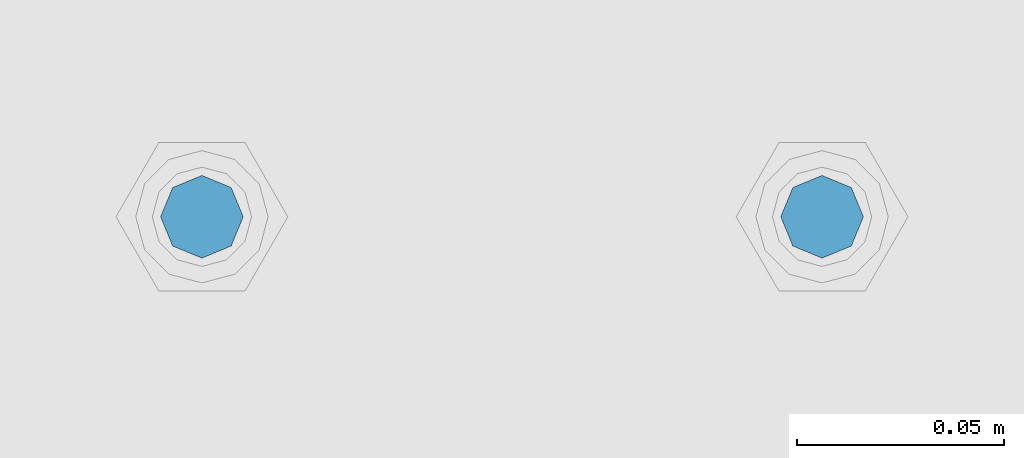
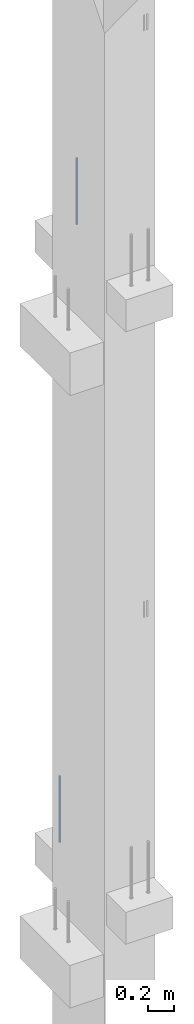
# One storey, part 14 of 41: 2 beams, 1 element without a shape of its own.
"""IFC2X3 building model written with IfcOpenShell, lengths in millimetres."""

import ifcopenshell
import ifcopenshell.guid

model = None  # the IFC model being written
_history = None  # IfcOwnerHistory: only IFC2X3 demands one
_inside = {}  # id of a spatial element -> (the spatial element, [elements in it])
_under = {}  # id of a project, library or spatial element -> (it, [spatial elements below it])
_declared = {}  # id of a project -> (the project, [libraries it declares])
_typed = {}  # id of a type object -> (the type object, [elements of that type])
_made_of = {}  # id of a material, layer set ... -> (it, [elements and type objects made of it])


def new_model(schema):
    """Start an empty IFC model of exactly this schema.

    Asked for "IFC4X3", IfcOpenShell would pick the latest addendum, in which some entities
    have other attributes; the version numbers below select the first issue.
    IFC2X3 requires an IfcOwnerHistory on every rooted entity: one is made here for all.
    """
    global model, _history
    if schema == "IFC4X3":
        model = ifcopenshell.file(schema_version=(4, 3, 0, 0))
    else:
        model = ifcopenshell.file(schema=schema)
    _inside.clear()
    _under.clear()
    _declared.clear()
    _typed.clear()
    _made_of.clear()
    _history = None
    if model.schema == "IFC2X3":
        org = make("IfcOrganization", Name="unknown")
        user = make(
            "IfcPersonAndOrganization",
            ThePerson=make("IfcPerson", FamilyName="unknown"),
            TheOrganization=org,
        )
        app = make(
            "IfcApplication",
            ApplicationDeveloper=org,
            Version="unknown",
            ApplicationFullName="unknown",
            ApplicationIdentifier="unknown",
        )
        _history = make(
            "IfcOwnerHistory",
            OwningUser=user,
            OwningApplication=app,
            ChangeAction="ADDED",
            CreationDate=0,
        )
    return model


def make(cls, **values):
    """One entity of the class cls with the attributes given. An attribute that is None is left unset."""
    return model.create_entity(
        cls, **{name: value for name, value in values.items() if value is not None}
    )


def rooted(cls, **values):
    """An entity with a GlobalId (a new one), such as an element, a storey or a relation."""
    return make(cls, GlobalId=ifcopenshell.guid.new(), OwnerHistory=_history, **values)


def si_unit(unit_type, name, prefix=None):
    """IfcSIUnit, for example si_unit("LENGTHUNIT", "METRE", prefix="MILLI")."""
    return make("IfcSIUnit", UnitType=unit_type, Prefix=prefix, Name=name)


def assignment(units):
    """IfcUnitAssignment: the units of a project."""
    return None if units is None else make("IfcUnitAssignment", Units=units)


def point(xyz):
    """IfcCartesianPoint."""
    return None if xyz is None else make("IfcCartesianPoint", Coordinates=xyz)


def direction(xyz):
    """IfcDirection."""
    return None if xyz is None else make("IfcDirection", DirectionRatios=xyz)


def frame(location, z_axis=None, x_axis=None):
    """IfcAxis2Placement3D, a coordinate frame: its origin and axes. An axis left out is left unset."""
    return make(
        "IfcAxis2Placement3D",
        Location=point(location),
        Axis=direction(z_axis),
        RefDirection=direction(x_axis),
    )


def origin_with_axes():
    """The frame at (0, 0, 0) with the z axis (0, 0, 1) and the x axis (1, 0, 0) written out."""
    return frame((0.0, 0.0, 0.0), z_axis=(0.0, 0.0, 1.0), x_axis=(1.0, 0.0, 0.0))


def place(relative_to, where):
    """IfcLocalPlacement: puts the frame where relative to a parent placement (None: the world)."""
    return make(
        "IfcLocalPlacement", PlacementRelTo=relative_to, RelativePlacement=where
    )


def context(
    kind, dimensions, precision=None, world=None, true_north=None, identifier=None
):
    """IfcGeometricRepresentationContext, for example the 3D "Model" context."""
    return make(
        "IfcGeometricRepresentationContext",
        ContextIdentifier=identifier,
        ContextType=kind,
        CoordinateSpaceDimension=dimensions,
        Precision=precision,
        WorldCoordinateSystem=world,
        TrueNorth=true_north,
    )


def subcontext(parent, identifier, kind, view, scale=None):
    """IfcGeometricRepresentationSubContext, for example "Body" below "Model"."""
    return make(
        "IfcGeometricRepresentationSubContext",
        ContextIdentifier=identifier,
        ContextType=kind,
        ParentContext=parent,
        TargetScale=scale,
        TargetView=view,
    )


def project(units=None, contexts=None):
    """IfcProject with its units and contexts."""
    return rooted(
        "IfcProject",
        Name="project",
        RepresentationContexts=contexts,
        UnitsInContext=assignment(units),
    )


def spatial(cls, under=None, at=None, **own):
    """A site, building, storey or space (cls), placed at a placement, below another one or the project."""
    s = rooted(cls, ObjectPlacement=at, **own)
    if under is not None:
        _under.setdefault(under.id(), (under, []))[1].append(s)
    return s


def faces_of(points, faces, orient=None, outer=None):
    """IfcFace entities. A face is a list of loops; a loop is a list of indices into points, from 0.

    orient and outer hold one flag for each loop. By default every Orientation is true, the
    first loop of a face is its IfcFaceOuterBound and the others are IfcFaceBound.
    """
    made = []
    for i, loops in enumerate(faces):
        bounds = []
        for j, loop in enumerate(loops):
            is_outer = j == 0 if outer is None else outer[i][j]
            bounds.append(
                make(
                    "IfcFaceOuterBound" if is_outer else "IfcFaceBound",
                    Bound=make("IfcPolyLoop", Polygon=[points[k] for k in loop]),
                    Orientation=True if orient is None else orient[i][j],
                )
            )
        made.append(make("IfcFace", Bounds=bounds))
    return made


def faceted_brep(points, faces, orient=None, outer=None, voids=None):
    """IfcFacetedBrep: a solid bounded by flat faces; with voids (closed shells), ...WithVoids."""
    shared = [point(p) for p in points]
    hull = make("IfcClosedShell", CfsFaces=faces_of(shared, faces, orient, outer))
    if voids is None:
        return make("IfcFacetedBrep", Outer=hull)
    return make(
        "IfcFacetedBrepWithVoids",
        Outer=hull,
        Voids=[
            make(cls, CfsFaces=faces_of(shared, fs, o, b)) for cls, fs, o, b in voids
        ],
    )


def shape(context_of_items, identifier, shape_type, items):
    """IfcShapeRepresentation: the items that make up one representation, for example the "Body"."""
    return make(
        "IfcShapeRepresentation",
        ContextOfItems=context_of_items,
        RepresentationIdentifier=identifier,
        RepresentationType=shape_type,
        Items=items,
    )


def material(Name=None, Category=None):
    """IfcMaterial."""
    return make("IfcMaterial", Name=Name, Category=Category)


def made_of(thing, what):
    """Note that an element or type object is made of a material, layer set ...; save() writes the relation."""
    if what is not None:
        _made_of.setdefault(what.id(), (what, []))[1].append(thing)
    return thing


def type_object(cls, material=None, **own):
    """A type object (cls), such as IfcWallType, which elements share."""
    return made_of(rooted(cls, **own), material)


def element(
    cls,
    number,
    at=None,
    inside=None,
    cuts=None,
    type_object=None,
    material=None,
    context=None,
    identifier="Body",
    shape_type=None,
    held_by="IfcProductDefinitionShape",
    body=None,
    shapes=None,
    **own,
):
    """One element of the class cls, such as IfcWall. Its Tag is "e" and its number.

    at: its placement. inside: the storey or other place that contains it. cuts: it is an
    opening in that element (IfcRelVoidsElement). A single representation is given by context,
    identifier, shape_type and body (its items); several are given by shapes. held_by: the class
    of the entity that holds the representations. save() writes the other relations.
    """
    e = rooted(cls, Tag="e%d" % number, ObjectPlacement=at, **own)
    if body is not None:
        shapes = [shape(context, identifier, shape_type, body)]
    if shapes is not None:
        e.Representation = make(held_by, Representations=shapes)
    if inside is not None:
        _inside.setdefault(inside.id(), (inside, []))[1].append(e)
    if cuts is not None:
        rooted(
            "IfcRelVoidsElement", RelatingBuildingElement=cuts, RelatedOpeningElement=e
        )
    if type_object is not None:
        _typed.setdefault(type_object.id(), (type_object, []))[1].append(e)
    return made_of(e, material)


def aggregate(whole, parts):
    """IfcRelAggregates: a whole, such as a stair, and the parts it consists of."""
    return rooted("IfcRelAggregates", RelatingObject=whole, RelatedObjects=parts)


def save(model, path):
    """Write the relations noted so far, then the file.

    IfcRelAggregates (storeys below a building ...), IfcRelContainedInSpatialStructure (elements
    in a storey), IfcRelDefinesByType, IfcRelAssociatesMaterial and IfcRelDeclares: one each for
    every whole, place, type object, material and project.
    """
    for whole, parts in _under.values():
        aggregate(whole, parts)
    for where, things in _inside.values():
        rooted(
            "IfcRelContainedInSpatialStructure",
            RelatedElements=things,
            RelatingStructure=where,
        )
    for kind, things in _typed.values():
        rooted("IfcRelDefinesByType", RelatedObjects=things, RelatingType=kind)
    for what, things in _made_of.values():
        rooted("IfcRelAssociatesMaterial", RelatedObjects=things, RelatingMaterial=what)
    for by, libraries in _declared.values():
        rooted("IfcRelDeclares", RelatingContext=by, RelatedDefinitions=libraries)
    model.write(path)


model = new_model("IFC2X3")

# Units and contexts
model_context = context("Model", 3, precision=1e-05, world=origin_with_axes())
body_context = subcontext(model_context, "Body", "Model", "MODEL_VIEW")
ifc_project = project(units=[si_unit("LENGTHUNIT", "METRE", prefix="MILLI"), si_unit("AREAUNIT", "SQUARE_METRE"), si_unit("VOLUMEUNIT", "CUBIC_METRE"), si_unit("MASSUNIT", "GRAM", prefix="KILO"), si_unit("TIMEUNIT", "SECOND"), si_unit("PLANEANGLEUNIT", "RADIAN"), si_unit("SOLIDANGLEUNIT", "STERADIAN"), si_unit("THERMODYNAMICTEMPERATUREUNIT", "DEGREE_CELSIUS"), si_unit("LUMINOUSINTENSITYUNIT", "LUMEN")], contexts=[model_context])

# Site, building, storey
site_placement = place(None, frame((-177556.685383467, -198018.589999756, 1290.0), z_axis=(0.0, 0.0, 1.0), x_axis=(0.788225611989142, -0.615386370180835, 0.0)))
site = spatial("IfcSite", under=ifc_project, at=site_placement, CompositionType="ELEMENT")
building_placement = place(site_placement, origin_with_axes())
building = spatial("IfcBuilding", under=site, at=building_placement, Name="Undefined", CompositionType="ELEMENT")
storey_placement = place(building_placement, origin_with_axes())
storey = spatial("IfcBuildingStorey", under=building, at=storey_placement, Name="Undefined", CompositionType="ELEMENT", Elevation=0.0)

# Assembly, beams
assembly_placement = place(storey_placement, origin_with_axes())
assembly = element("IfcElementAssembly", 1, at=assembly_placement, inside=storey, AssemblyPlace="NOTDEFINED", PredefinedType="REINFORCEMENT_UNIT")
ifc_material = material(Name="STEEL/S235JR")
beam_type = type_object("IfcBeamType", PredefinedType="NOTDEFINED")
beam_1_placement = place(assembly_placement, frame((17817.4400881731, 265828.966471616, 11990.0), z_axis=(-0.615386219627735, 0.788225729529483, 0.0), x_axis=(0.0, 0.0, -1.0)))
beam_1 = element("IfcBeam", 2, at=beam_1_placement, type_object=beam_type, material=ifc_material, context=body_context, shape_type="Brep", body=[
    faceted_brep([(4.88085788674653e-07, -10.0, -3.86498868465424e-08), (0.0, -7.07106819456385, -7.07106766643119), (624.0, -7.0710680251359, -7.07106751203537), (624.0, -10.0000002132438, 2.99856765195727e-07), (4.97872867461239e-11, -3.88578058618805e-15, -10.0), (624.0, -2.13272869586945e-07, -9.99999970020144), (0.0, 7.07106742914766, -7.0710676664894), (624.0, 7.07106759861927, -7.07106751209358), (4.88085788674653e-07, 10.0, -3.86498868465424e-08), (624.0, 9.99999978675623, 2.99711246043444e-07), (0.0, 7.07106742919132, 7.07106795720756), (624.0, 7.07106759864837, 7.07106811160338), (-4.97872867461239e-11, 0.0, 10.0), (624.0, -2.13214661926031e-07, 10.0000002997695), (0.0, -7.07106819453475, 7.07106795729487), (624.0, -7.0710680251068, 7.07106811166159)], [[[0, 1, 2, 3]], [[1, 4, 5, 2]], [[4, 6, 7, 5]], [[6, 8, 9, 7]], [[8, 10, 11, 9]], [[10, 12, 13, 11]], [[12, 14, 15, 13]], [[14, 0, 3, 15]], [[5, 7, 9, 11, 13, 15, 3, 2]], [[14, 12, 10, 8, 6, 4, 1, 0]]]),
])
beam_2_placement = place(assembly_placement, frame((17699.206246375, 265736.658516089, 6230.0), z_axis=(-0.615386219627735, 0.788225729529483, 0.0), x_axis=(0.0, 0.0, -1.0)))
beam_2 = element("IfcBeam", 3, at=beam_2_placement, type_object=beam_type, material=ifc_material, context=body_context, shape_type="Brep", body=[
    faceted_brep([(4.88085788674653e-07, -10.0, -3.86498868465424e-08), (0.0, -7.07106819456385, -7.07106766643119), (624.0, -7.0710680251359, -7.07106751203537), (624.0, -10.0000002132438, 2.99856765195727e-07), (4.97872867461239e-11, -3.88578058618805e-15, -10.0), (624.0, -2.13272869586945e-07, -9.99999970020144), (0.0, 7.07106742914766, -7.0710676664894), (624.0, 7.07106759861927, -7.07106751209358), (4.88085788674653e-07, 10.0, -3.86498868465424e-08), (624.0, 9.99999978675623, 2.99711246043444e-07), (0.0, 7.07106742919132, 7.07106795720756), (624.0, 7.07106759864837, 7.07106811160338), (-4.97872867461239e-11, 0.0, 10.0), (624.0, -2.13214661926031e-07, 10.0000002997695), (0.0, -7.07106819453475, 7.07106795729487), (624.0, -7.0710680251068, 7.07106811166159)], [[[0, 1, 2, 3]], [[1, 4, 5, 2]], [[4, 6, 7, 5]], [[6, 8, 9, 7]], [[8, 10, 11, 9]], [[10, 12, 13, 11]], [[12, 14, 15, 13]], [[14, 0, 3, 15]], [[5, 7, 9, 11, 13, 15, 3, 2]], [[14, 12, 10, 8, 6, 4, 1, 0]]]),
])
aggregate(assembly, [beam_1, beam_2])

save(model, "model.ifc")
